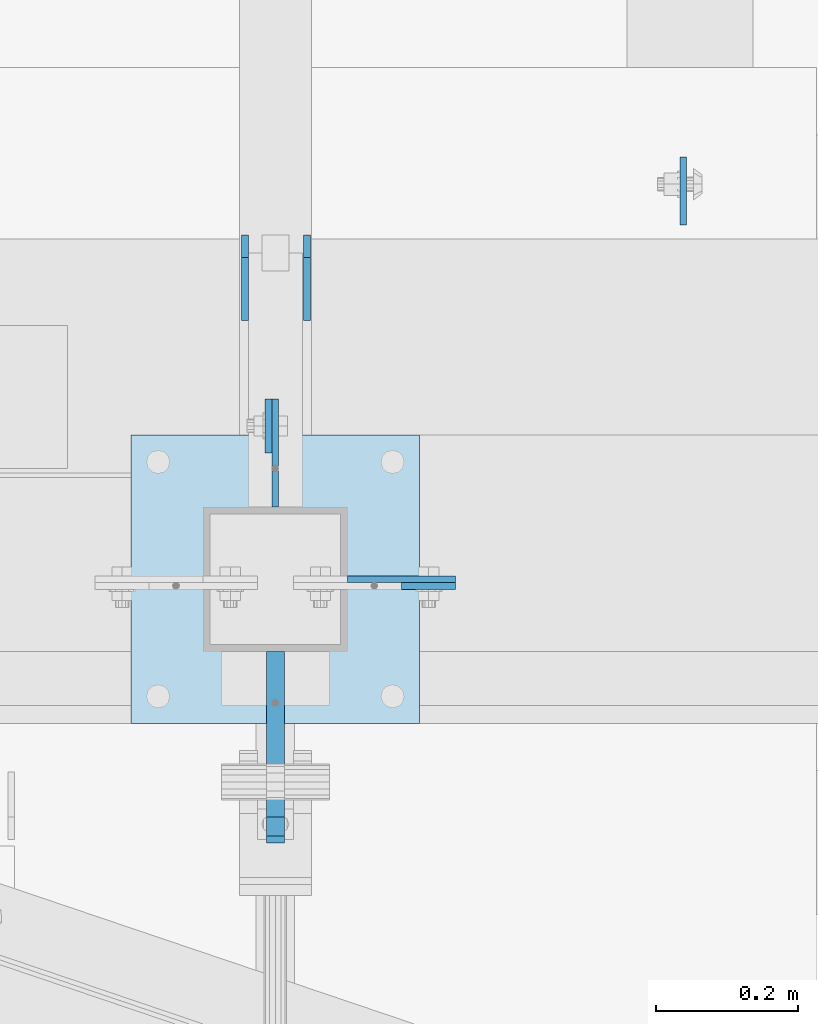
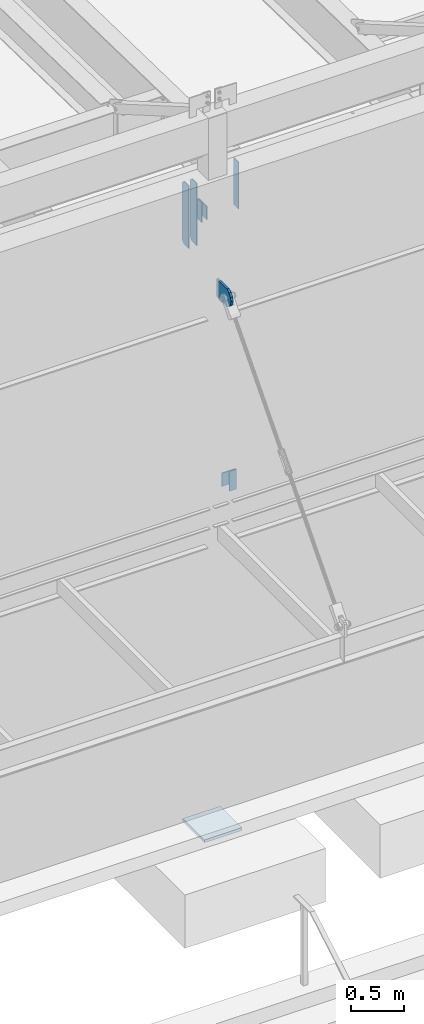
# One storey, part 1466 of 1763: 9 plates, 4 elements without a shape of their own.
"""IFC2X3 building model written with IfcOpenShell, lengths in millimetres."""

from ifc_helpers import new_model, si_unit, frame, origin_with_axes, place, context, subcontext, project, spatial, faceted_brep, material, type_object, element, aggregate, save


model = new_model("IFC2X3")

# Units and contexts
model_context = context("Model", 3, precision=1e-05, world=origin_with_axes())
body_context = subcontext(model_context, "Body", "Model", "MODEL_VIEW")
ifc_project = project(units=[si_unit("LENGTHUNIT", "METRE", prefix="MILLI"), si_unit("AREAUNIT", "SQUARE_METRE"), si_unit("VOLUMEUNIT", "CUBIC_METRE"), si_unit("MASSUNIT", "GRAM", prefix="KILO"), si_unit("TIMEUNIT", "SECOND"), si_unit("PLANEANGLEUNIT", "RADIAN"), si_unit("SOLIDANGLEUNIT", "STERADIAN"), si_unit("THERMODYNAMICTEMPERATUREUNIT", "DEGREE_CELSIUS"), si_unit("LUMINOUSINTENSITYUNIT", "LUMEN")], contexts=[model_context])

# Site, building, storey
site_placement = place(None, origin_with_axes())
site = spatial("IfcSite", under=ifc_project, at=site_placement, CompositionType="ELEMENT")
building_placement = place(site_placement, origin_with_axes())
building = spatial("IfcBuilding", under=site, at=building_placement, Name="Undefined", CompositionType="ELEMENT")
storey_placement = place(building_placement, origin_with_axes())
storey = spatial("IfcBuildingStorey", under=building, at=storey_placement, Name="Undefined", CompositionType="ELEMENT", Elevation=0.0)

# Assembly, plate
assembly_1_placement = place(storey_placement, origin_with_axes())
assembly_1 = element("IfcElementAssembly", 1, at=assembly_1_placement, inside=storey, Name="BEAM", AssemblyPlace="NOTDEFINED", PredefinedType="RIGID_FRAME")
ifc_material = material(Name="STEEL/A36")
plate_type_1 = type_object("IfcPlateType", PredefinedType="NOTDEFINED")
plate_1_placement = place(assembly_1_placement, frame((-52028.1520100205, -14030.3276093311, 11863.3875), z_axis=(0.0, 0.0, 1.0), x_axis=(0.0, 1.0, 0.0)))
plate_1 = element("IfcPlate", 2, at=plate_1_placement, type_object=plate_type_1, material=ifc_material, Name="PLATE", context=body_context, shape_type="Brep", body=[
    faceted_brep([(0.0, -4.76249999999982, 0.0), (-2.83762346953154e-10, -4.7624999996915, 228.600006103516), (-2.83762346953154e-10, 4.76250000028813, 228.600006103517), (0.0, 4.76249999999982, 0.0), (76.1999969480166, -4.76249999961874, 228.600006103516), (76.1999969480166, 4.76250000036089, 228.600006103517), (76.1999969482931, -4.76249999991705, 0.0), (76.1999969482931, 4.76250000006257, 1.81898940354586e-12)], [[[0, 1, 2, 3]], [[1, 4, 5, 2]], [[4, 6, 7, 5]], [[6, 0, 3, 7]], [[5, 7, 3, 2]], [[6, 4, 1, 0]]]),
])
aggregate(assembly_1, [plate_1])

assembly_2_placement = place(storey_placement, origin_with_axes())
assembly_2 = element("IfcElementAssembly", 3, at=assembly_2_placement, inside=storey, Name="BEAM", AssemblyPlace="NOTDEFINED", PredefinedType="RIGID_FRAME")
plate_2_placement = place(assembly_2_placement, frame((-51840.8269962897, -14217.6525879036, 8839.2), z_axis=(0.0, 0.0, 1.0), x_axis=(1.0, 0.0, 0.0)))
plate_2 = element("IfcPlate", 4, at=plate_2_placement, type_object=plate_type_1, material=ifc_material, Name="PLATE", context=body_context, shape_type="Brep", body=[
    faceted_brep([(0.0, -4.76249999999982, 0.0), (-2.83762346953154e-10, -4.7624999996915, 228.600006103516), (-2.83762346953154e-10, 4.76250000028813, 228.600006103517), (0.0, 4.76249999999982, 0.0), (76.1999969480166, -4.76249999961874, 228.600006103516), (76.1999969480166, 4.76250000036089, 228.600006103517), (76.1999969482931, -4.76249999991705, 0.0), (76.1999969482931, 4.76250000006257, 1.81898940354586e-12)], [[[0, 1, 2, 3]], [[1, 4, 5, 2]], [[4, 6, 7, 5]], [[6, 0, 3, 7]], [[5, 7, 3, 2]], [[6, 4, 1, 0]]]),
])
aggregate(assembly_2, [plate_2])

# Assembly, plates
assembly_3_placement = place(storey_placement, origin_with_axes())
assembly_3 = element("IfcElementAssembly", 5, at=assembly_3_placement, inside=storey, Name="BEAM", AssemblyPlace="NOTDEFINED", PredefinedType="RIGID_FRAME")
plate_type_2 = type_object("IfcPlateType", PredefinedType="NOTDEFINED")
plate_3_placement = place(assembly_3_placement, frame((-52061.4895083209, -13843.7935686171, 11466.5125), z_axis=(0.0, 0.0, 1.0), x_axis=(0.0, 1.0, 0.0)))
plate_3 = element("IfcPlate", 6, at=plate_3_placement, type_object=plate_type_2, material=ifc_material, Name="PLATE", context=body_context, shape_type="Brep", body=[
    faceted_brep([(0.0, -4.76249999999982, 0.0), (0.0, -4.76249999999709, 717.549987792969), (0.0, 4.76249999999709, 717.549987792969), (0.0, 4.76249999999982, 0.0), (88.9000015258789, -4.76249999999709, 717.549987792969), (88.9000015258789, 4.76249999999709, 717.549987792969), (120.650001525879, -4.76249999999709, 685.799987792969), (120.650001525879, 4.76249999999709, 685.799987792969), (120.650001525879, -4.76249999999709, 31.75), (120.650001525879, 4.76249999999709, 31.75), (88.9000015258789, -4.76249999999709, 0.0), (88.9000015258789, 4.76249999999709, 0.0)], [[[0, 1, 2, 3]], [[1, 4, 5, 2]], [[4, 6, 7, 5]], [[6, 8, 9, 7]], [[8, 10, 11, 9]], [[10, 0, 3, 11]], [[5, 7, 9, 11, 3, 2]], [[10, 8, 6, 4, 1, 0]]]),
])
plate_4_placement = place(assembly_3_placement, frame((-51974.1780083209, -13843.7935686171, 11466.5125), z_axis=(0.0, 0.0, 1.0), x_axis=(0.0, 1.0, 0.0)))
plate_4 = element("IfcPlate", 7, at=plate_4_placement, type_object=plate_type_2, material=ifc_material, Name="PLATE", context=body_context, shape_type="Brep", body=[
    faceted_brep([(0.0, -4.76249999999982, 0.0), (0.0, -4.76249999999709, 717.549987792969), (0.0, 4.76249999999709, 717.549987792969), (0.0, 4.76249999999982, 0.0), (88.9000015258789, -4.76249999999709, 717.549987792969), (88.9000015258789, 4.76249999999709, 717.549987792969), (120.650001525879, -4.76249999999709, 685.799987792969), (120.650001525879, 4.76249999999709, 685.799987792969), (120.650001525879, -4.76249999999709, 31.75), (120.650001525879, 4.76249999999709, 31.75), (88.9000015258789, -4.76249999999709, 0.0), (88.9000015258789, 4.76249999999709, 0.0)], [[[0, 1, 2, 3]], [[1, 4, 5, 2]], [[4, 6, 7, 5]], [[6, 8, 9, 7]], [[8, 10, 11, 9]], [[10, 0, 3, 11]], [[5, 7, 9, 11, 3, 2]], [[10, 8, 6, 4, 1, 0]]]),
])

assembly_4_placement = place(storey_placement, origin_with_axes())
assembly_4 = element("IfcElementAssembly", 8, at=assembly_4_placement, inside=storey, Name="COLUMN", AssemblyPlace="NOTDEFINED", PredefinedType="RIGID_FRAME")
plate_type_3 = type_object("IfcPlateType", PredefinedType="NOTDEFINED")
plate_5_placement = place(assembly_4_placement, frame((-52018.6270115205, -13954.1276123353, 12091.9875061035), z_axis=(0.0, 0.0, -1.0), x_axis=(0.0, -1.0, 0.0)))
plate_5 = element("IfcPlate", 9, at=plate_5_placement, type_object=plate_type_3, material=ifc_material, Name="PLATE", context=body_context, shape_type="Brep", body=[
    faceted_brep([(0.0, -4.76249999999982, 0.0), (-3.05175672110636e-06, -4.7625000002663, 152.399993896484), (-3.05175490211695e-06, 4.76249999972788, 152.399993896484), (0.0, 4.76249999999982, 0.0), (152.400009155272, -4.76249999975698, 152.399993896484), (152.400009155273, 4.76250000024447, 152.399993896484), (152.400009155272, -4.76249999948777, 5.45696821063757e-12), (152.400009155273, 4.76250000051368, 3.63797880709171e-12)], [[[0, 1, 2, 3]], [[1, 4, 5, 2]], [[4, 6, 7, 5]], [[6, 0, 3, 7]], [[5, 7, 3, 2]], [[6, 4, 1, 0]]]),
])
plate_6_placement = place(assembly_4_placement, frame((-51764.626999389, -14208.127588641, 9067.80000610352), z_axis=(0.0, 0.0, -1.0), x_axis=(-1.0, 0.0, 0.0)))
plate_6 = element("IfcPlate", 10, at=plate_6_placement, type_object=plate_type_3, material=ifc_material, Name="PLATE", context=body_context, shape_type="Brep", body=[
    faceted_brep([(0.0, -4.76249999999982, 0.0), (-3.05175672110636e-06, -4.7625000002663, 152.399993896484), (-3.05175490211695e-06, 4.76249999972788, 152.399993896484), (0.0, 4.76249999999982, 0.0), (152.400009155272, -4.76249999975698, 152.399993896484), (152.400009155273, 4.76250000024447, 152.399993896484), (152.400009155272, -4.76249999948777, 5.45696821063757e-12), (152.400009155273, 4.76250000051368, 3.63797880709171e-12)], [[[0, 1, 2, 3]], [[1, 4, 5, 2]], [[4, 6, 7, 5]], [[6, 0, 3, 7]], [[5, 7, 3, 2]], [[6, 4, 1, 0]]]),
])
plate_type_4 = type_object("IfcPlateType", PredefinedType="NOTDEFINED")
plate_7_placement = place(assembly_4_placement, frame((-52018.627008321, -14503.4026217954, 11188.7000003081), z_axis=(0.0, 0.0, 1.0), x_axis=(0.0, 1.0, 0.0)))
plate_7 = element("IfcPlate", 11, at=plate_7_placement, type_object=plate_type_4, material=ifc_material, Name="PLATE", context=body_context, shape_type="Brep", body=[
    faceted_brep([(0.0, -12.6999999999971, -1.81898940354586e-12), (-39.5764506670585, -12.6999999999971, 21.5331529121049), (-39.5764506670585, 12.6999999999971, 21.5331529121049), (0.0, 12.6999999999971, -1.81898940354586e-12), (-66.6095773920388, -12.6999999999971, 57.5773227764421), (-66.6095773920388, 12.6999999999971, 57.5773227764421), (-76.199996948335, -12.6999999999971, 101.599998461508), (-76.199996948335, 12.6999999999971, 101.599998461508), (-66.6095774066125, -12.6999999999971, 145.622674149748), (-66.6095774066125, 12.6999999999971, 145.622674149748), (-39.5764506935648, -12.6999999999971, 181.666844023039), (-39.5764506935648, 12.6999999999971, 181.666844023039), (-3.36349330609664e-08, -12.6999999999971, 203.199996948242), (-3.36349330609664e-08, 12.6999999999971, 203.199996948242), (193.675003051578, -12.6999999999971, 203.199996948413), (193.675003051578, 12.6999999999971, 203.199996948413), (193.675003051758, -12.6999999999971, 3.09228198602796e-10), (193.675003051758, 12.6999999999971, 3.09228198602796e-10)], [[[0, 1, 2, 3]], [[1, 4, 5, 2]], [[4, 6, 7, 5]], [[6, 8, 9, 7]], [[8, 10, 11, 9]], [[10, 12, 13, 11]], [[12, 14, 15, 13]], [[14, 16, 17, 15]], [[16, 0, 3, 17]], [[5, 7, 9, 11, 13, 15, 17, 3, 2]], [[16, 14, 12, 10, 8, 6, 4, 1, 0]]]),
])

# Plate
plate_type_5 = type_object("IfcPlateType", PredefinedType="NOTDEFINED")
plate_8_placement = place(assembly_3_placement, frame((-51443.9622736983, -13708.8560686171, 12154.1242990454), z_axis=(0.0, 1.0, 0.0), x_axis=(0.0, 0.0, -1.0)))
plate_8 = element("IfcPlate", 12, at=plate_8_placement, type_object=plate_type_5, material=ifc_material, Name="PLATE", context=body_context, shape_type="Brep", body=[
    faceted_brep([(0.0, -4.76249999999982, 0.0), (0.0, -4.76249999999709, 95.25), (0.0, 4.76249999999709, 95.25), (0.0, 4.76249999999982, 0.0), (533.400024414062, -4.76249999999709, 95.25), (533.400024414062, 4.76249999999709, 95.25), (533.400024414062, -4.76250000000073, 0.0), (533.400024414062, 4.76250000000073, 0.0)], [[[0, 1, 2, 3]], [[1, 4, 5, 2]], [[4, 6, 7, 5]], [[6, 0, 3, 7]], [[5, 7, 3, 2]], [[6, 4, 1, 0]]]),
])

aggregate(assembly_3, [plate_3, plate_4, plate_8])

plate_type_6 = type_object("IfcPlateType", PredefinedType="NOTDEFINED")
plate_9_placement = place(assembly_4_placement, frame((-52221.8270083209, -14004.9275894107, 5083.17499999999), z_axis=(1.0, 0.0, 0.0), x_axis=(0.0, -1.0, 0.0)))
plate_9 = element("IfcPlate", 13, at=plate_9_placement, type_object=plate_type_6, material=ifc_material, Name="PLATE", context=body_context, shape_type="Brep", body=[
    faceted_brep([(0.0, -15.875, 0.0), (0.0, -15.875, 406.399993896484), (0.0, 15.875, 406.399993896484), (0.0, 15.875, 0.0), (406.399993896484, -15.875, 406.399993896484), (406.399993896484, 15.875, 406.399993896484), (406.399993896484, -15.875, 0.0), (406.399993896484, 15.875, 0.0)], [[[0, 1, 2, 3]], [[1, 4, 5, 2]], [[4, 6, 7, 5]], [[6, 0, 3, 7]], [[5, 7, 3, 2]], [[6, 4, 1, 0]]]),
])

aggregate(assembly_4, [plate_5, plate_6, plate_7, plate_9])

save(model, "model.ifc")
